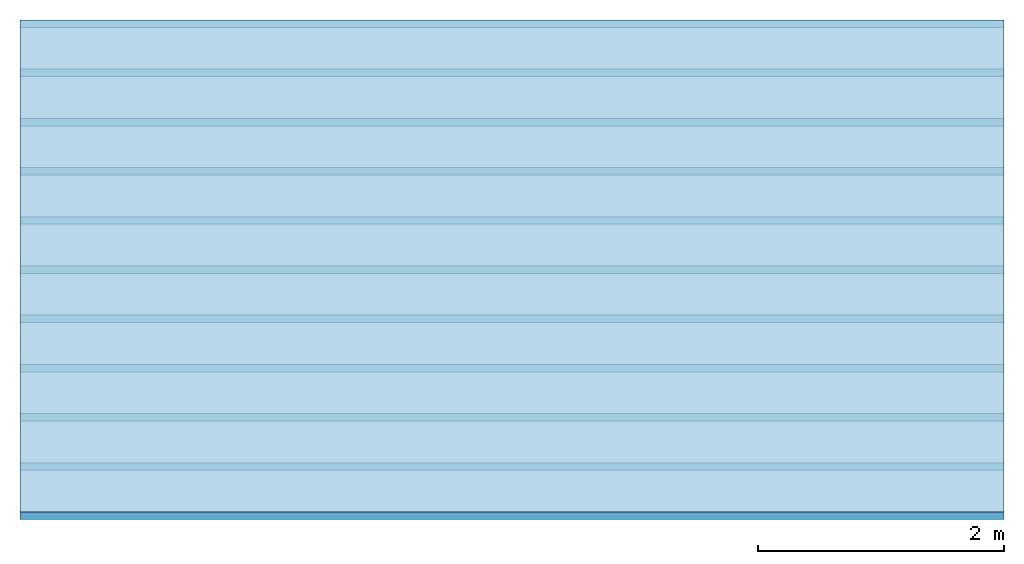
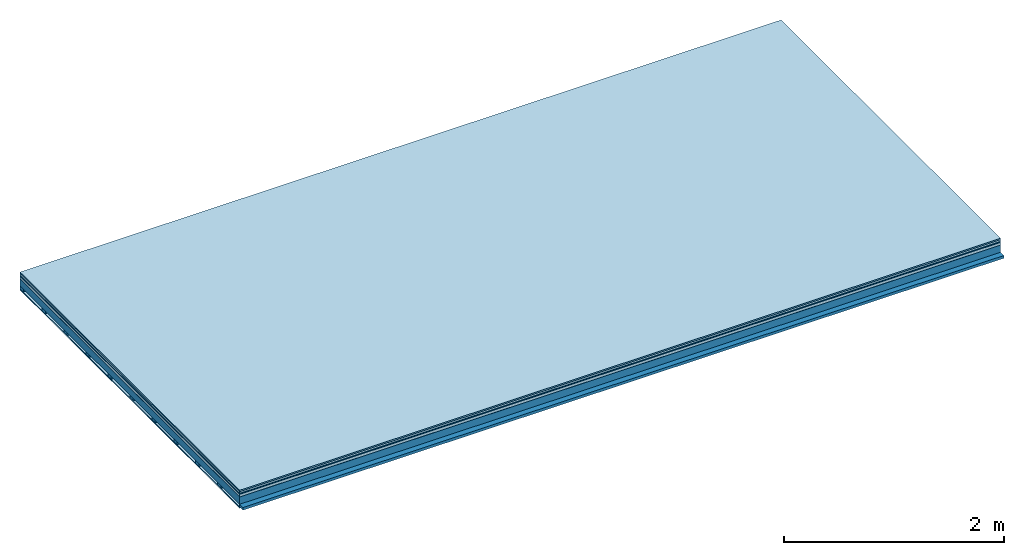
# One storey: 7 plates, 2 members, 1 element without a shape of its own.
"""IFC4 building model written with IfcOpenShell, lengths in metres."""

from ifc_helpers import new_model, si_unit, derived_unit, direction, frame, frame_2d, origin, origin_with_axes, place, context, project, spatial, rectangle, extrude, material, layer, layer_set, type_object, element, aggregate, save


model = new_model("IFC4")

# Units and contexts
plan_context = context("Plan", 3, precision=1e-05, world=origin(), true_north=direction((0.0, 1.0)))
model_context = context("Model", 3, precision=1e-05, world=origin(), true_north=direction((0.0, 1.0)))
ifc_project = project(units=[si_unit("LENGTHUNIT", "METRE"), derived_unit("SOUNDPRESSUREUNIT", [(si_unit("PRESSUREUNIT", "PASCAL", prefix="MICRO"), 0)]), si_unit("ENERGYUNIT", "JOULE", prefix="MEGA"), si_unit("MASSUNIT", "GRAM", prefix="KILO"), derived_unit("THERMALTRANSMITTANCEUNIT", [(si_unit("POWERUNIT", "WATT"), 1), (si_unit("AREAUNIT", "SQUARE_METRE"), -1), (si_unit("THERMODYNAMICTEMPERATUREUNIT", "KELVIN"), -1)]), derived_unit("AREADENSITYUNIT", [(si_unit("MASSUNIT", "GRAM", prefix="KILO"), 1), (si_unit("AREAUNIT", "SQUARE_METRE"), -1)]), derived_unit("USERDEFINED", [(si_unit("ENERGYUNIT", "JOULE", prefix="MEGA"), 1), (si_unit("AREAUNIT", "SQUARE_METRE"), -1)])], contexts=[plan_context, model_context])

# Site, building, storey
site = spatial("IfcSite", under=ifc_project)
building_placement = place(None, origin())
building = spatial("IfcBuilding", under=site, at=building_placement)
storey_placement = place(building_placement, origin())
storey = spatial("IfcBuildingStorey", under=building, at=storey_placement)

# Slab, members, plates
ifc_material_1 = material(Category="11.013")
ifc_layer_1 = layer(ifc_material_1, 0.015, Name="Flooring")
ifc_material_2 = material(Category="03.007")
ifc_layer_2 = layer(ifc_material_2, 0.02, Name="On-material")
ifc_material_3 = material(Name="Wood fiber generic product", Category="10.009")
ifc_layer_3 = layer(ifc_material_3, 0.01, Name="Impact sound insulation")
ifc_material_4 = material(Name="with broken")
ifc_layer_4 = layer(ifc_material_4, 0.03, Name="on Supporting structure")
ifc_material_5 = material(Name="protection", Category="09.007")
ifc_layer_5 = layer(ifc_material_5, 0.0005, Name="Sub-floor")
ifc_material_6 = material(Name="no composite action")
ifc_layer_6 = layer(ifc_material_6, 0.0, Name="Bond")
ifc_layer_7 = layer(None, 0.08, Name="Supporting structure")
ifc_material_7 = material(Name="of the art")
ifc_layer_8 = layer(ifc_material_7, 0.0, Name="Bond")
ifc_layer_9 = layer(None, 0.03, Name="Battens / profiles")
ifc_material_8 = material(Name="Plasterboard type A", Category="03.008")
ifc_layer_10 = layer(ifc_material_8, 0.0125, Name="Ceiling covering 1st layer")
ifc_material_9 = material(Category="04.001")
ifc_layer_11 = layer(ifc_material_9, 0.003, Name="Surface / treatment")
ifc_layer_set = layer_set([ifc_layer_1, ifc_layer_2, ifc_layer_3, ifc_layer_4, ifc_layer_5, ifc_layer_6, ifc_layer_7, ifc_layer_8, ifc_layer_9, ifc_layer_10, ifc_layer_11])
slab_type = type_object("IfcSlabType", Name="A2103", PredefinedType="NOTDEFINED", material=ifc_layer_set)
slab_placement = place(None, frame((0.0, 0.0, 0.0), z_axis=(0.0, 0.0, -1.0), x_axis=(1.0, 0.0, 0.0)))
slab = element("IfcSlab", 1, at=slab_placement, inside=storey, type_object=slab_type, material=ifc_layer_set, Name="Slab #1")
ifc_material_10 = material(Name="Solid timber panel")
member_1_placement = place(slab_placement, origin())
member_1 = element("IfcMember", 2, at=member_1_placement, material=ifc_material_10, Name="Supporting structure", context=plan_context, shape_type="SweptSolid", body=[
    extrude(rectangle(XDim=1.0, YDim=0.08, at=frame_2d((0.5, 0.04), x_axis=(1.0, 0.0))), frame((0.0, 4.0, 0.0755), z_axis=(0.0, -1.0, 0.0), x_axis=(1.0, 0.0, 0.0)), (0.0, 0.0, 1.0), 4.0),
    extrude(rectangle(XDim=1.0, YDim=0.08, at=frame_2d((0.5, 0.04), x_axis=(1.0, 0.0))), frame((1.0, 4.0, 0.0755), z_axis=(0.0, -1.0, 0.0), x_axis=(1.0, 0.0, 0.0)), (0.0, 0.0, 1.0), 4.0),
    extrude(rectangle(XDim=1.0, YDim=0.08, at=frame_2d((0.5, 0.04), x_axis=(1.0, 0.0))), frame((2.0, 4.0, 0.0755), z_axis=(0.0, -1.0, 0.0), x_axis=(1.0, 0.0, 0.0)), (0.0, 0.0, 1.0), 4.0),
    extrude(rectangle(XDim=1.0, YDim=0.08, at=frame_2d((0.5, 0.04), x_axis=(1.0, 0.0))), frame((3.0, 4.0, 0.0755), z_axis=(0.0, -1.0, 0.0), x_axis=(1.0, 0.0, 0.0)), (0.0, 0.0, 1.0), 4.0),
    extrude(rectangle(XDim=1.0, YDim=0.08, at=frame_2d((0.5, 0.04), x_axis=(1.0, 0.0))), frame((4.0, 4.0, 0.0755), z_axis=(0.0, -1.0, 0.0), x_axis=(1.0, 0.0, 0.0)), (0.0, 0.0, 1.0), 4.0),
    extrude(rectangle(XDim=1.0, YDim=0.08, at=frame_2d((0.5, 0.04), x_axis=(1.0, 0.0))), frame((5.0, 4.0, 0.0755), z_axis=(0.0, -1.0, 0.0), x_axis=(1.0, 0.0, 0.0)), (0.0, 0.0, 1.0), 4.0),
    extrude(rectangle(XDim=1.0, YDim=0.08, at=frame_2d((0.5, 0.04), x_axis=(1.0, 0.0))), frame((6.0, 4.0, 0.0755), z_axis=(0.0, -1.0, 0.0), x_axis=(1.0, 0.0, 0.0)), (0.0, 0.0, 1.0), 4.0),
    extrude(rectangle(XDim=1.0, YDim=0.08, at=frame_2d((0.5, 0.04), x_axis=(1.0, 0.0))), frame((7.0, 4.0, 0.0755), z_axis=(0.0, -1.0, 0.0), x_axis=(1.0, 0.0, 0.0)), (0.0, 0.0, 1.0), 4.0),
])
ifc_material_11 = material()
member_2_placement = place(slab_placement, origin())
member_2 = element("IfcMember", 3, at=member_2_placement, material=ifc_material_11, Name="Battens / profiles", context=plan_context, shape_type="SweptSolid", body=[
    extrude(rectangle(XDim=0.06, YDim=0.03, at=frame_2d((0.03, 0.015), x_axis=(1.0, 0.0))), frame((0.0, 0.0, 0.1555), z_axis=(1.0, 0.0, 0.0), x_axis=(0.0, 1.0, 0.0)), (0.0, 0.0, 1.0), 8.0),
    extrude(rectangle(XDim=0.06, YDim=0.03, at=frame_2d((0.03, 0.015), x_axis=(1.0, 0.0))), frame((0.0, 0.4, 0.1555), z_axis=(1.0, 0.0, 0.0), x_axis=(0.0, 1.0, 0.0)), (0.0, 0.0, 1.0), 8.0),
    extrude(rectangle(XDim=0.06, YDim=0.03, at=frame_2d((0.03, 0.015), x_axis=(1.0, 0.0))), frame((0.0, 0.8, 0.1555), z_axis=(1.0, 0.0, 0.0), x_axis=(0.0, 1.0, 0.0)), (0.0, 0.0, 1.0), 8.0),
    extrude(rectangle(XDim=0.06, YDim=0.03, at=frame_2d((0.03, 0.015), x_axis=(1.0, 0.0))), frame((0.0, 1.2, 0.1555), z_axis=(1.0, 0.0, 0.0), x_axis=(0.0, 1.0, 0.0)), (0.0, 0.0, 1.0), 8.0),
    extrude(rectangle(XDim=0.06, YDim=0.03, at=frame_2d((0.03, 0.015), x_axis=(1.0, 0.0))), frame((0.0, 1.6, 0.1555), z_axis=(1.0, 0.0, 0.0), x_axis=(0.0, 1.0, 0.0)), (0.0, 0.0, 1.0), 8.0),
    extrude(rectangle(XDim=0.06, YDim=0.03, at=frame_2d((0.03, 0.015), x_axis=(1.0, 0.0))), frame((0.0, 2.0, 0.1555), z_axis=(1.0, 0.0, 0.0), x_axis=(0.0, 1.0, 0.0)), (0.0, 0.0, 1.0), 8.0),
    extrude(rectangle(XDim=0.06, YDim=0.03, at=frame_2d((0.03, 0.015), x_axis=(1.0, 0.0))), frame((0.0, 2.4, 0.1555), z_axis=(1.0, 0.0, 0.0), x_axis=(0.0, 1.0, 0.0)), (0.0, 0.0, 1.0), 8.0),
    extrude(rectangle(XDim=0.06, YDim=0.03, at=frame_2d((0.03, 0.015), x_axis=(1.0, 0.0))), frame((0.0, 2.8, 0.1555), z_axis=(1.0, 0.0, 0.0), x_axis=(0.0, 1.0, 0.0)), (0.0, 0.0, 1.0), 8.0),
    extrude(rectangle(XDim=0.06, YDim=0.03, at=frame_2d((0.03, 0.015), x_axis=(1.0, 0.0))), frame((0.0, 3.2, 0.1555), z_axis=(1.0, 0.0, 0.0), x_axis=(0.0, 1.0, 0.0)), (0.0, 0.0, 1.0), 8.0),
    extrude(rectangle(XDim=0.06, YDim=0.03, at=frame_2d((0.03, 0.015), x_axis=(1.0, 0.0))), frame((0.0, 3.6, 0.1555), z_axis=(1.0, 0.0, 0.0), x_axis=(0.0, 1.0, 0.0)), (0.0, 0.0, 1.0), 8.0),
    extrude(rectangle(XDim=0.06, YDim=0.03, at=frame_2d((0.03, 0.015), x_axis=(1.0, 0.0))), frame((0.0, 4.0, 0.1555), z_axis=(1.0, 0.0, 0.0), x_axis=(0.0, 1.0, 0.0)), (0.0, 0.0, 1.0), 8.0),
])
plate_1_placement = place(slab_placement, origin())
plate_1 = element("IfcPlate", 4, at=plate_1_placement, material=ifc_material_1, Name="Flooring", context=plan_context, shape_type="SweptSolid", body=[
    extrude(rectangle(XDim=8.0, YDim=4.0, at=frame_2d((4.0, 2.0), x_axis=(1.0, 0.0))), origin_with_axes(), (0.0, 0.0, 1.0), 0.015),
])
plate_2_placement = place(slab_placement, origin())
plate_2 = element("IfcPlate", 5, at=plate_2_placement, material=ifc_material_2, Name="On-material", context=plan_context, shape_type="SweptSolid", body=[
    extrude(rectangle(XDim=8.0, YDim=4.0, at=frame_2d((4.0, 2.0), x_axis=(1.0, 0.0))), frame((0.0, 0.0, 0.015), z_axis=(0.0, 0.0, 1.0), x_axis=(1.0, 0.0, 0.0)), (0.0, 0.0, 1.0), 0.02),
])
plate_3_placement = place(slab_placement, origin())
plate_3 = element("IfcPlate", 6, at=plate_3_placement, material=ifc_material_3, Name="Impact sound insulation", context=plan_context, shape_type="SweptSolid", body=[
    extrude(rectangle(XDim=8.0, YDim=4.0, at=frame_2d((4.0, 2.0), x_axis=(1.0, 0.0))), frame((0.0, 0.0, 0.035), z_axis=(0.0, 0.0, 1.0), x_axis=(1.0, 0.0, 0.0)), (0.0, 0.0, 1.0), 0.01),
])
plate_4_placement = place(slab_placement, origin())
plate_4 = element("IfcPlate", 7, at=plate_4_placement, material=ifc_material_4, Name="on Supporting structure", context=plan_context, shape_type="SweptSolid", body=[
    extrude(rectangle(XDim=8.0, YDim=4.0, at=frame_2d((4.0, 2.0), x_axis=(1.0, 0.0))), frame((0.0, 0.0, 0.045), z_axis=(0.0, 0.0, 1.0), x_axis=(1.0, 0.0, 0.0)), (0.0, 0.0, 1.0), 0.03),
])
plate_5_placement = place(slab_placement, origin())
plate_5 = element("IfcPlate", 8, at=plate_5_placement, material=ifc_material_5, Name="Sub-floor", context=plan_context, shape_type="SweptSolid", body=[
    extrude(rectangle(XDim=8.0, YDim=4.0, at=frame_2d((4.0, 2.0), x_axis=(1.0, 0.0))), frame((0.0, 0.0, 0.075), z_axis=(0.0, 0.0, 1.0), x_axis=(1.0, 0.0, 0.0)), (0.0, 0.0, 1.0), 0.0005),
])
plate_6_placement = place(slab_placement, origin())
plate_6 = element("IfcPlate", 9, at=plate_6_placement, material=ifc_material_8, Name="Ceiling covering 1st layer", context=plan_context, shape_type="SweptSolid", body=[
    extrude(rectangle(XDim=8.0, YDim=4.0, at=frame_2d((4.0, 2.0), x_axis=(1.0, 0.0))), frame((0.0, 0.0, 0.1855), z_axis=(0.0, 0.0, 1.0), x_axis=(1.0, 0.0, 0.0)), (0.0, 0.0, 1.0), 0.0125),
])
plate_7_placement = place(slab_placement, origin())
plate_7 = element("IfcPlate", 10, at=plate_7_placement, material=ifc_material_9, Name="Surface / treatment", context=plan_context, shape_type="SweptSolid", body=[
    extrude(rectangle(XDim=8.0, YDim=4.0, at=frame_2d((4.0, 2.0), x_axis=(1.0, 0.0))), frame((0.0, 0.0, 0.198), z_axis=(0.0, 0.0, 1.0), x_axis=(1.0, 0.0, 0.0)), (0.0, 0.0, 1.0), 0.003),
])
aggregate(slab, [plate_1, plate_2, plate_3, plate_4, plate_5, member_1, member_2, plate_6, plate_7])

save(model, "model.ifc")
